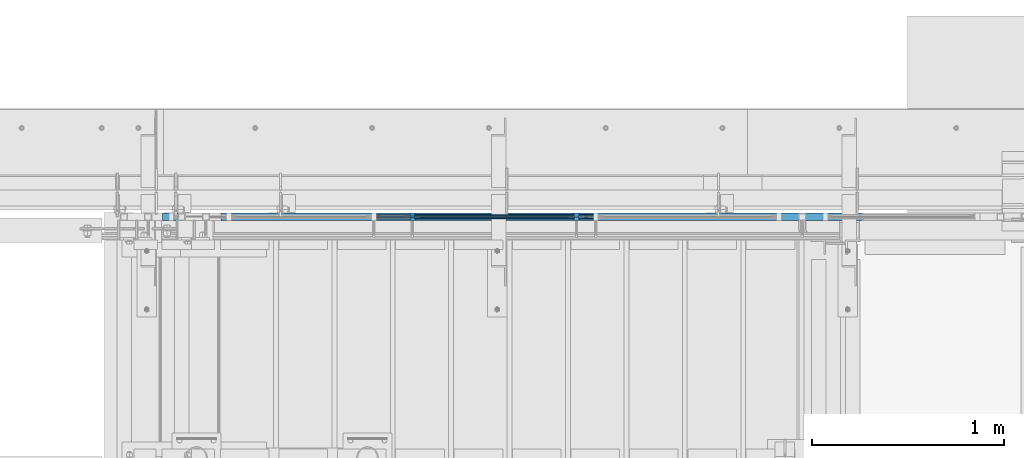
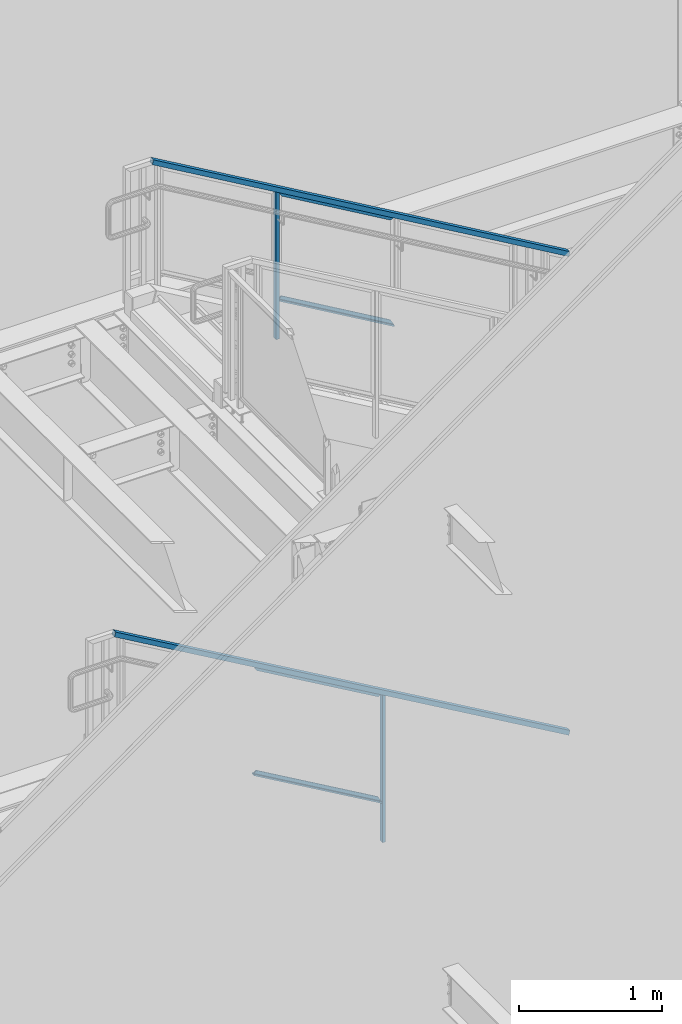
# One storey, part 797 of 1179: 6 members, 4 beams, 2 elements without a shape of their own.
"""IFC2X3 building model written with IfcOpenShell, lengths in millimetres."""

from ifc_helpers import new_model, si_unit, frame, origin_with_axes, place, context, subcontext, project, spatial, faceted_brep, material, type_object, element, aggregate, save


model = new_model("IFC2X3")

# Units and contexts
model_context = context("Model", 3, precision=1e-05, world=origin_with_axes())
body_context = subcontext(model_context, "Body", "Model", "MODEL_VIEW")
ifc_project = project(units=[si_unit("LENGTHUNIT", "METRE", prefix="MILLI"), si_unit("AREAUNIT", "SQUARE_METRE"), si_unit("VOLUMEUNIT", "CUBIC_METRE"), si_unit("MASSUNIT", "GRAM", prefix="KILO"), si_unit("TIMEUNIT", "SECOND"), si_unit("PLANEANGLEUNIT", "RADIAN"), si_unit("SOLIDANGLEUNIT", "STERADIAN"), si_unit("THERMODYNAMICTEMPERATUREUNIT", "DEGREE_CELSIUS"), si_unit("LUMINOUSINTENSITYUNIT", "LUMEN")], contexts=[model_context])

# Site, building, storey
site_placement = place(None, origin_with_axes())
site = spatial("IfcSite", under=ifc_project, at=site_placement, CompositionType="ELEMENT")
building_placement = place(site_placement, origin_with_axes())
building = spatial("IfcBuilding", under=site, at=building_placement, Name="Undefined", CompositionType="ELEMENT")
storey_placement = place(building_placement, origin_with_axes())
storey = spatial("IfcBuildingStorey", under=building, at=storey_placement, Name="Undefined", CompositionType="ELEMENT", Elevation=0.0)

# Assembly, member
assembly_1_placement = place(storey_placement, origin_with_axes())
assembly_1 = element("IfcElementAssembly", 1, at=assembly_1_placement, inside=storey, Name="GUARDRAIL", AssemblyPlace="NOTDEFINED", PredefinedType="RIGID_FRAME")
ifc_material_1 = material(Name="STEEL/A36")
member_type_1 = type_object("IfcMemberType", PredefinedType="NOTDEFINED")
member_1_placement = place(assembly_1_placement, frame((20810.0083338412, 41065.449999238, 7355.33459459014), z_axis=(0.0, -1.0, 0.0), x_axis=(0.0, 0.0, 1.0)))
member_1 = element("IfcMember", 2, at=member_1_placement, type_object=member_type_1, material=ifc_material_1, Name="POST", context=body_context, shape_type="Brep", body=[
    faceted_brep([(0.0, 12.7000000000007, -19.0500000000029), (0.0, 12.7000000000007, 19.0500000000029), (1257.9937907086, 12.7000000000007, 19.0500000000029), (1257.9937907086, 12.7000000000007, -19.0500000000029), (0.0, -12.7000000000007, 19.0500000000029), (1243.17712405909, -12.7000000000007, 19.0500000000029), (0.0, -12.7000000000007, -19.0500000000029), (1243.17712405909, -12.7000000000007, -19.0500000000029)], [[[0, 1, 2, 3]], [[1, 4, 5, 2]], [[4, 6, 7, 5]], [[6, 0, 3, 7]], [[5, 7, 3, 2]], [[6, 4, 1, 0]]]),
])

assembly_2_placement = place(storey_placement, origin_with_axes())
assembly_2 = element("IfcElementAssembly", 3, at=assembly_2_placement, inside=storey, Name="GUARDRAIL", AssemblyPlace="NOTDEFINED", PredefinedType="RIGID_FRAME")
member_2_placement = place(assembly_2_placement, frame((21666.1999246046, 41065.4499993604, 2776.27547491143), z_axis=(0.0, -1.0, 0.0), x_axis=(0.0, 0.0, 1.0)))
member_2 = element("IfcMember", 4, at=member_2_placement, type_object=member_type_1, material=ifc_material_1, Name="POST", context=body_context, shape_type="Brep", body=[
    faceted_brep([(0.0, 12.7000000000007, -19.0500000000029), (0.0, 12.7000000000007, 19.0500000000029), (1257.59245944594, 12.7000000000007, 19.0500000000029), (1257.59245944594, 12.7000000000007, -19.0500000000029), (0.0, -12.7000000000007, 19.0500000000029), (1242.88603583053, -12.7000000000007, 19.0500000000029), (0.0, -12.7000000000007, -19.0500000000029), (1242.88603583053, -12.7000000000007, -19.0500000000029)], [[[0, 1, 2, 3]], [[1, 4, 5, 2]], [[4, 6, 7, 5]], [[6, 0, 3, 7]], [[5, 7, 3, 2]], [[6, 4, 1, 0]]]),
])

# Beam
ifc_material_2 = material(Name="STEEL/BUY-OUT")
beam_type = type_object("IfcBeamType", PredefinedType="NOTDEFINED")
beam_1_placement = place(assembly_1_placement, frame((21251.7195235769, 41062.2751647691, 7467.07850346958), z_axis=(0.863778851027978, 0.0, -0.503871111016285), x_axis=(-0.503871111016286, 0.0, -0.863778851027978)))
beam_1 = element("IfcBeam", 5, at=beam_1_placement, type_object=beam_type, material=ifc_material_2, Name="U-EDGE", context=body_context, shape_type="Brep", body=[
    faceted_brep([(3.02679836750031e-09, 1.58750000000146, -465.424288071716), (3.02316038869321e-09, -1.58750000000146, -465.424288071717), (-3.58704710379243e-09, -1.58750000000146, 550.296660657488), (-3.58704710379243e-09, 1.58750000000146, 550.296660657488), (22.2250000928143, 1.58750000000146, -478.189679507572), (22.2250000632448, 1.58750000000146, 588.991208057043), (22.2250000826898, 4.76250001285371, -478.189679501758), (22.2250000757122, 4.76249998416461, 588.991208078747), (1.59241608344018e-07, 4.76250000984146, -465.424288161439), (1.58372131409124e-07, 4.76249998836283, 550.296660939461), (1.59241608344018e-07, 7.93750000983709, -465.424288161439), (1.58372131409124e-07, 7.93749998836574, 550.296660939461), (25.4000000827036, 7.93750001290027, -480.013306842378), (25.4000000343149, 7.9375, 594.519), (25.4000000928609, -1.58750000000146, -480.013306848216), (25.4000000343149, -1.58750000000146, 594.519)], [[[0, 1, 2, 3]], [[4, 0, 3, 5]], [[6, 4, 5, 7]], [[8, 6, 7, 9]], [[10, 8, 9, 11]], [[12, 10, 11, 13]], [[14, 12, 13, 15]], [[11, 9, 7, 5, 3, 2, 15, 13]], [[1, 14, 15, 2]], [[0, 4, 6, 8, 10, 12, 14, 1]]]),
])

beam_2_placement = place(assembly_1_placement, frame((21226.1228752194, 41062.2751647691, 8331.94304219308), z_axis=(0.863778851027978, 0.0, -0.503871111016285), x_axis=(0.503871025088838, 0.0, 0.863778901152328)))
beam_2 = element("IfcBeam", 6, at=beam_2_placement, type_object=beam_type, material=ifc_material_2, Name="U-EDGE", context=body_context, shape_type="Brep", body=[
    faceted_brep([(-1.33470166474581e-07, -4.76249999994616, -435.790965618296), (-1.33470166474581e-07, -7.93749999994907, -435.790965618296), (-1.34041329147294e-07, -7.93750000006548, 579.929993147438), (-1.34041329147294e-07, -4.76250000006257, 579.929993147438), (22.224999933358, -4.76249999989523, -474.486507128395), (22.2249999328378, -4.76250000012806, 592.695373883196), (22.2249999333071, -1.58750000000146, -474.486507128307), (22.2249999328997, -1.58750000000146, 592.695373883229), (2.25554686039686e-10, -1.58750000000146, -435.790965851076), (0.0, -1.58750000000146, 579.92999369853), (2.25554686039686e-10, 1.58750000000146, -435.790965851076), (0.0, 1.58750000000146, 579.92999369853), (25.39999993331, 1.58750000000146, -480.014441613133), (25.3999999489688, 1.58750000000146, 594.519), (25.399999933361, -7.93749999989086, -480.014441613221), (25.3999999489688, -7.9375, 594.519)], [[[0, 1, 2, 3]], [[4, 0, 3, 5]], [[6, 4, 5, 7]], [[8, 6, 7, 9]], [[10, 8, 9, 11]], [[12, 10, 11, 13]], [[14, 12, 13, 15]], [[11, 9, 7, 5, 3, 2, 15, 13]], [[1, 14, 15, 2]], [[0, 4, 6, 8, 10, 12, 14, 1]]]),
])

beam_3_placement = place(assembly_2_placement, frame((21150.1372838082, 41062.2751647691, 3443.58608981394), z_axis=(0.86540914081268, 0.0, -0.501065882891521), x_axis=(-0.501065882891527, 0.0, -0.865409140812677)))
beam_3 = element("IfcBeam", 7, at=beam_3_placement, type_object=beam_type, material=ifc_material_2, Name="U-EDGE", context=body_context, shape_type="Brep", body=[
    faceted_brep([(-2.17914930544794e-09, 1.58750000000146, -579.8750616161), (-2.17914930544794e-09, -1.58750000000146, -579.8750616161), (2.06819095183164e-09, -1.58750000000146, 550.462303003866), (2.06819095183164e-09, 1.58750000000146, 550.462303003866), (22.2250000220702, 1.58750000000146, -592.688577145202), (22.225000051898, 1.58750000000146, 589.01191290709), (22.225000034794, 4.76249998386629, -592.688577152541), (22.2250000392505, 4.7625000160333, 589.011912885151), (7.50696926843375e-08, 4.76249998754065, -579.875061660634), (7.28450686438009e-08, 4.7625000118278, 550.462303126626), (7.50696926843375e-08, 7.93749998753628, -579.875061660634), (7.28450686438009e-08, 7.93750001182343, 550.462303126626), (25.4000000347896, 7.93749998381099, -594.518999999977), (25.4000000343149, 7.9375, 594.519), (25.4000000220258, -1.58750000000146, -594.518999999807), (25.4000000343149, -1.58750000000146, 594.519)], [[[0, 1, 2, 3]], [[4, 0, 3, 5]], [[6, 4, 5, 7]], [[8, 6, 7, 9]], [[10, 8, 9, 11]], [[12, 10, 11, 13]], [[14, 12, 13, 15]], [[11, 9, 7, 5, 3, 2, 15, 13]], [[1, 14, 15, 2]], [[0, 4, 6, 8, 10, 12, 14, 1]]]),
])

beam_4_placement = place(assembly_2_placement, frame((21124.6831741915, 41062.2751647691, 4309.2613638706), z_axis=(0.86540914081268, 0.0, -0.501065882891521), x_axis=(0.501065882891522, 0.0, 0.865409140812679)))
beam_4 = element("IfcBeam", 8, at=beam_4_placement, type_object=beam_type, material=ifc_material_2, Name="U-EDGE", context=body_context, shape_type="Brep", body=[
    faceted_brep([(-5.08043740410358e-09, -4.76250001176231, -550.462297073285), (-5.08043740410358e-09, -7.93750001176522, -550.462297073285), (2.06819095183164e-09, -7.93749998760177, 579.875144306196), (2.06819095183164e-09, -4.76249998760613, 579.875144306196), (22.2249999989635, -4.76250001590233, -589.011912123857), (22.2249999997566, -4.76249998399726, 592.68851804268), (22.2250000115582, -1.58750000000146, -589.011912145696), (22.2249999870892, -1.58750000000146, 592.68851803538), (-3.47426976077259e-10, -1.58750000000146, -550.462297081494), (3.69254848919809e-10, -1.58750000000146, 579.875144305217), (-3.47426976077259e-10, 1.58750000000146, -550.462297081494), (3.69254848919809e-10, 1.58750000000146, 579.875144305217), (25.4000001784334, 1.58750000000146, -594.51900000087), (25.3999999489688, 1.58750000000146, 594.519), (25.4000002532193, -7.93749990531796, -594.51900000187), (25.3999999489688, -7.9375, 594.519)], [[[0, 1, 2, 3]], [[4, 0, 3, 5]], [[6, 4, 5, 7]], [[8, 6, 7, 9]], [[10, 8, 9, 11]], [[12, 10, 11, 13]], [[14, 12, 13, 15]], [[11, 9, 7, 5, 3, 2, 15, 13]], [[1, 14, 15, 2]], [[0, 4, 6, 8, 10, 12, 14, 1]]]),
])

# Member
ifc_material_3 = material()
member_type_2 = type_object("IfcMemberType", Name="HSS1-1/2X1-1/2X1/8", PredefinedType="NOTDEFINED")
member_3_placement = place(assembly_1_placement, frame((19805.65, 41065.4499992355, 9213.8499999772), z_axis=(0.503871025088838, 0.0, 0.863778901152328), x_axis=(0.863778851027978, 0.0, -0.503871111016285)))
member_3 = element("IfcMember", 9, at=member_3_placement, type_object=member_type_2, material=ifc_material_3, Name="GUARDRAIL", ObjectType="HSS1-1/2X1-1/2X1/8", context=body_context, shape_type="Brep", body=[
    faceted_brep([(4.29179236063283, 15.874999282998, -15.8749992829871), (4.29179236063283, -15.874999282998, -15.8749992829871), (3885.84064798419, -15.874999282998, -15.8749992821213), (3885.84064798419, 15.874999282998, -15.8749992821213), (-4.29179248428773, -15.874999282998, 15.8749992829871), (3877.25706314817, -15.874999282998, 15.874999283853), (-4.29179248428773, 15.874999282998, 15.8749992829871), (3877.25706314817, 15.874999282998, 15.874999283853), (5.15015087091524, 19.0499992350015, -19.0499992349833), (-5.15015099456832, 19.0499992350015, 19.0499992349833), (3876.39870463878, 19.0499992350015, 19.0499992358527), (3886.69900649359, 19.0499992350015, -19.0499992341174), (-5.15015099456832, -19.0499992350015, 19.0499992349833), (3876.39870463878, -19.0499992350015, 19.0499992358527), (5.15015087091524, -19.0499992350015, -19.0499992349833), (3886.69900649359, -19.0499992350015, -19.0499992341174)], [[[0, 1, 2, 3]], [[1, 4, 5, 2]], [[4, 6, 7, 5]], [[6, 0, 3, 7]], [[8, 9, 10, 11]], [[9, 12, 13, 10]], [[12, 14, 15, 13]], [[14, 8, 11, 15]], [[13, 15, 11, 10], [5, 7, 3, 2]], [[14, 12, 9, 8], [6, 4, 1, 0]]]),
])

member_4_placement = place(assembly_2_placement, frame((19500.8500008816, 41065.4499993594, 5302.2500002004), z_axis=(0.501065882891522, 0.0, 0.865409140812679), x_axis=(0.86540914081268, 0.0, -0.501065882891521)))
member_4 = element("IfcMember", 10, at=member_4_placement, type_object=member_type_2, material=ifc_material_3, Name="GUARDRAIL", ObjectType="HSS1-1/2X1-1/2X1/8", context=body_context, shape_type="Brep", body=[
    faceted_brep([(4.26416977440931, 15.874999282998, -15.8749992829853), (4.26416977440931, -15.874999282998, -15.8749992829853), (4230.70439077224, -15.874999282998, -15.8749992810754), (4230.70439077224, 15.874999282998, -15.8749992810754), (-4.2641689637494, -15.874999282998, 15.8749992829908), (4222.17605203408, -15.874999282998, 15.8749992849025), (-4.2641689637494, 15.874999282998, 15.8749992829908), (4222.17605203408, 15.874999282998, 15.8749992849025), (5.11700367385129, 19.0499992350015, -19.0499992349851), (-5.11700286318955, 19.0499992350015, 19.0499992349887), (4221.32321813464, 19.0499992350015, 19.0499992368987), (4231.55722467168, 19.0499992350015, -19.0499992330733), (-5.11700286318955, -19.0499992350015, 19.0499992349887), (4221.32321813464, -19.0499992350015, 19.0499992368987), (5.11700367385129, -19.0499992350015, -19.0499992349851), (4231.55722467168, -19.0499992350015, -19.0499992330733)], [[[0, 1, 2, 3]], [[1, 4, 5, 2]], [[4, 6, 7, 5]], [[6, 0, 3, 7]], [[8, 9, 10, 11]], [[9, 12, 13, 10]], [[12, 14, 15, 13]], [[14, 8, 11, 15]], [[13, 15, 11, 10], [5, 7, 3, 2]], [[14, 12, 9, 8], [6, 4, 1, 0]]]),
])

member_type_3 = type_object("IfcMemberType", PredefinedType="NOTDEFINED")
member_5_placement = place(assembly_1_placement, frame((20810.0083338412, 41065.449999238, 7686.14841716201), z_axis=(0.0, -1.0, 0.0), x_axis=(0.863778851027978, 0.0, -0.503871111016285)))
member_5 = element("IfcMember", 11, at=member_5_placement, type_object=member_type_3, material=ifc_material_1, Name="BOTTOM_RAIL", context=body_context, shape_type="Brep", body=[
    faceted_brep([(10.9986698874163, 6.34999999999854, -12.6999999999971), (10.9986698874163, 6.34999999999854, 12.6999999999971), (1089.20668431148, 6.35000000024229, 12.6999999999971), (1089.20668431148, 6.35000000024229, -12.6999999999971), (18.4070032121654, -6.34999999999127, 12.6999999999971), (1096.61501763624, -6.34999999974752, 12.6999999999971), (18.4070032121654, -6.34999999999127, -12.6999999999971), (1096.61501763624, -6.34999999974752, -12.6999999999971)], [[[0, 1, 2, 3]], [[1, 4, 5, 2]], [[4, 6, 7, 5]], [[6, 0, 3, 7]], [[5, 7, 3, 2]], [[6, 4, 1, 0]]]),
])

aggregate(assembly_1, [beam_1, beam_2, member_5, member_1, member_3])

member_6_placement = place(assembly_2_placement, frame((20608.9249611447, 41065.4499993604, 3718.62097896639), z_axis=(0.0, -1.0, 0.0), x_axis=(0.86540914081268, 0.0, -0.501065882891521)))
member_6 = element("IfcMember", 12, at=member_6_placement, type_object=member_type_3, material=ifc_material_1, Name="BOTTOM_RAIL", context=body_context, shape_type="Brep", body=[
    faceted_brep([(10.998533752896, 6.34999999999854, -12.6999999999971), (10.998533752896, 6.34999999999854, 12.6999999999971), (1203.35358848741, 6.35000000053878, 12.6999999999971), (1203.35358848741, 6.35000000053878, -12.6999999999971), (18.3517455606161, -6.34999999998945, 12.6999999999971), (1210.70680029513, -6.34999999944921, 12.6999999999971), (18.3517455606161, -6.34999999998945, -12.6999999999971), (1210.70680029513, -6.34999999944921, -12.6999999999971)], [[[0, 1, 2, 3]], [[1, 4, 5, 2]], [[4, 6, 7, 5]], [[6, 0, 3, 7]], [[5, 7, 3, 2]], [[6, 4, 1, 0]]]),
])

aggregate(assembly_2, [beam_3, beam_4, member_6, member_2, member_4])

save(model, "model.ifc")
